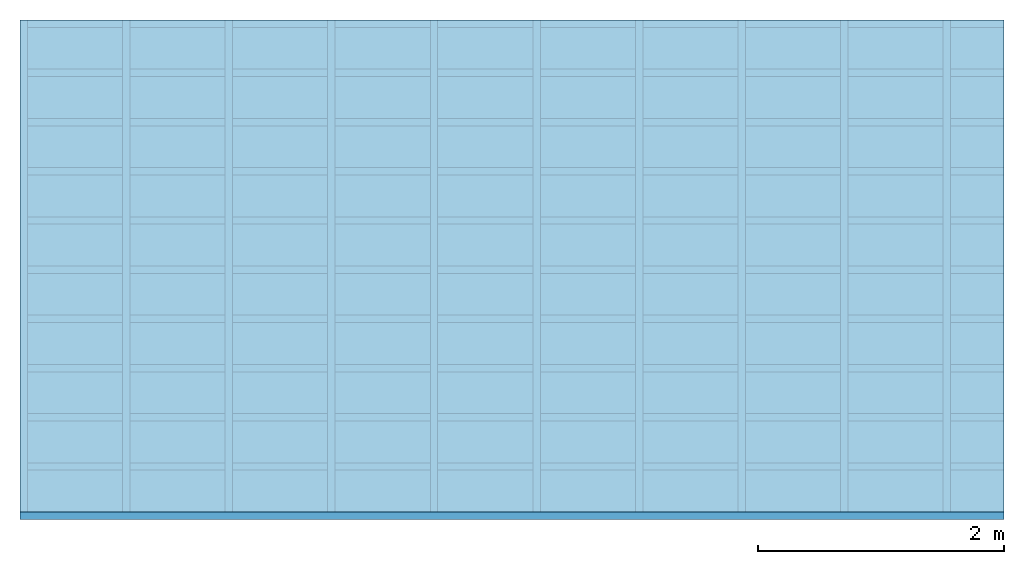
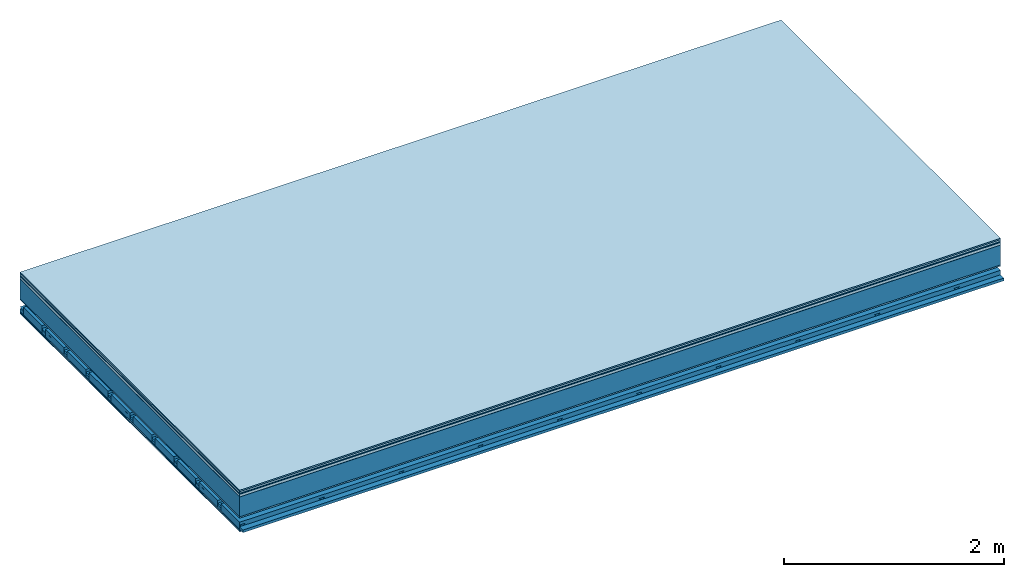
# One storey: 9 plates, 4 members, 1 element without a shape of its own.
"""IFC4 building model written with IfcOpenShell, lengths in metres."""

from ifc_helpers import new_model, si_unit, derived_unit, direction, frame, frame_2d, origin, origin_with_axes, place, context, project, spatial, polyline, rectangle, outline, extrude, material, layer, layer_set, type_object, element, aggregate, save


model = new_model("IFC4")

# Units and contexts
plan_context = context("Plan", 3, precision=1e-05, world=origin(), true_north=direction((0.0, 1.0)))
model_context = context("Model", 3, precision=1e-05, world=origin(), true_north=direction((0.0, 1.0)))
ifc_project = project(units=[si_unit("LENGTHUNIT", "METRE"), derived_unit("SOUNDPRESSUREUNIT", [(si_unit("PRESSUREUNIT", "PASCAL", prefix="MICRO"), 0)]), si_unit("ENERGYUNIT", "JOULE", prefix="MEGA"), si_unit("MASSUNIT", "GRAM", prefix="KILO"), derived_unit("THERMALTRANSMITTANCEUNIT", [(si_unit("POWERUNIT", "WATT"), 1), (si_unit("AREAUNIT", "SQUARE_METRE"), -1), (si_unit("THERMODYNAMICTEMPERATUREUNIT", "KELVIN"), -1)]), derived_unit("AREADENSITYUNIT", [(si_unit("MASSUNIT", "GRAM", prefix="KILO"), 1), (si_unit("AREAUNIT", "SQUARE_METRE"), -1)]), derived_unit("USERDEFINED", [(si_unit("ENERGYUNIT", "JOULE", prefix="MEGA"), 1), (si_unit("AREAUNIT", "SQUARE_METRE"), -1)])], contexts=[plan_context, model_context])

# Site, building, storey
site = spatial("IfcSite", under=ifc_project)
building_placement = place(None, origin())
building = spatial("IfcBuilding", under=site, at=building_placement)
storey_placement = place(building_placement, origin())
storey = spatial("IfcBuildingStorey", under=building, at=storey_placement)

# Slab, members, plates
ifc_material_1 = material(Category="11.013")
ifc_layer_1 = layer(ifc_material_1, 0.015, Name="Flooring")
ifc_material_2 = material(Category="03.007")
ifc_layer_2 = layer(ifc_material_2, 0.02, Name="On-material")
ifc_material_3 = material(Name="Wood fiber generic product", Category="10.009")
ifc_layer_3 = layer(ifc_material_3, 0.01, Name="Impact sound insulation")
ifc_material_4 = material(Name="with broken")
ifc_layer_4 = layer(ifc_material_4, 0.03, Name="on Supporting structure")
ifc_material_5 = material(Name="protection", Category="09.007")
ifc_layer_5 = layer(ifc_material_5, 0.0005, Name="Sub-floor")
ifc_material_6 = material(Name="no composite action")
ifc_layer_6 = layer(ifc_material_6, 0.0, Name="Bond")
ifc_layer_7 = layer(None, 0.22, Name="Supporting structure")
ifc_material_7 = material(Name="of the art")
ifc_layer_8 = layer(ifc_material_7, 0.0, Name="Bond")
ifc_layer_9 = layer(ifc_material_2, 0.015, Name="Lower layer 1")
ifc_layer_10 = layer(None, 0.095, Name="Coupling")
ifc_layer_11 = layer(None, 0.03, Name="Battens / profiles")
ifc_material_8 = material(Name="Plasterboard type A", Category="03.008")
ifc_layer_12 = layer(ifc_material_8, 0.0125, Name="Ceiling covering 1st layer")
ifc_layer_13 = layer(ifc_material_8, 0.0125, Name="Ceiling covering layer 2")
ifc_material_9 = material(Category="04.001")
ifc_layer_14 = layer(ifc_material_9, 0.003, Name="Surface / treatment")
ifc_layer_set = layer_set([ifc_layer_1, ifc_layer_2, ifc_layer_3, ifc_layer_4, ifc_layer_5, ifc_layer_6, ifc_layer_7, ifc_layer_8, ifc_layer_9, ifc_layer_10, ifc_layer_11, ifc_layer_12, ifc_layer_13, ifc_layer_14])
slab_type = type_object("IfcSlabType", Name="A2128", PredefinedType="NOTDEFINED", material=ifc_layer_set)
slab_placement = place(None, frame((0.0, 0.0, 0.0), z_axis=(0.0, 0.0, -1.0), x_axis=(1.0, 0.0, 0.0)))
slab = element("IfcSlab", 1, at=slab_placement, inside=storey, type_object=slab_type, material=ifc_layer_set, Name="Slab #1")
ifc_material_10 = material(Name="Solid timber panel")
member_1_placement = place(slab_placement, origin())
member_1 = element("IfcMember", 2, at=member_1_placement, material=ifc_material_10, Name="Supporting structure", context=plan_context, shape_type="SweptSolid", body=[
    extrude(rectangle(XDim=1.0, YDim=0.22, at=frame_2d((0.5, 0.11), x_axis=(1.0, 0.0))), frame((0.0, 4.0, 0.0755), z_axis=(0.0, -1.0, 0.0), x_axis=(1.0, 0.0, 0.0)), (0.0, 0.0, 1.0), 4.0),
    extrude(rectangle(XDim=1.0, YDim=0.22, at=frame_2d((0.5, 0.11), x_axis=(1.0, 0.0))), frame((1.0, 4.0, 0.0755), z_axis=(0.0, -1.0, 0.0), x_axis=(1.0, 0.0, 0.0)), (0.0, 0.0, 1.0), 4.0),
    extrude(rectangle(XDim=1.0, YDim=0.22, at=frame_2d((0.5, 0.11), x_axis=(1.0, 0.0))), frame((2.0, 4.0, 0.0755), z_axis=(0.0, -1.0, 0.0), x_axis=(1.0, 0.0, 0.0)), (0.0, 0.0, 1.0), 4.0),
    extrude(rectangle(XDim=1.0, YDim=0.22, at=frame_2d((0.5, 0.11), x_axis=(1.0, 0.0))), frame((3.0, 4.0, 0.0755), z_axis=(0.0, -1.0, 0.0), x_axis=(1.0, 0.0, 0.0)), (0.0, 0.0, 1.0), 4.0),
    extrude(rectangle(XDim=1.0, YDim=0.22, at=frame_2d((0.5, 0.11), x_axis=(1.0, 0.0))), frame((4.0, 4.0, 0.0755), z_axis=(0.0, -1.0, 0.0), x_axis=(1.0, 0.0, 0.0)), (0.0, 0.0, 1.0), 4.0),
    extrude(rectangle(XDim=1.0, YDim=0.22, at=frame_2d((0.5, 0.11), x_axis=(1.0, 0.0))), frame((5.0, 4.0, 0.0755), z_axis=(0.0, -1.0, 0.0), x_axis=(1.0, 0.0, 0.0)), (0.0, 0.0, 1.0), 4.0),
    extrude(rectangle(XDim=1.0, YDim=0.22, at=frame_2d((0.5, 0.11), x_axis=(1.0, 0.0))), frame((6.0, 4.0, 0.0755), z_axis=(0.0, -1.0, 0.0), x_axis=(1.0, 0.0, 0.0)), (0.0, 0.0, 1.0), 4.0),
    extrude(rectangle(XDim=1.0, YDim=0.22, at=frame_2d((0.5, 0.11), x_axis=(1.0, 0.0))), frame((7.0, 4.0, 0.0755), z_axis=(0.0, -1.0, 0.0), x_axis=(1.0, 0.0, 0.0)), (0.0, 0.0, 1.0), 4.0),
])
ifc_material_11 = material()
member_2_placement = place(slab_placement, origin())
member_2 = element("IfcMember", 3, at=member_2_placement, material=ifc_material_11, Name="Coupling", context=plan_context, shape_type="SweptSolid", body=[
    extrude(outline(polyline([(0.0, 0.0), (0.06, 0.0), (0.04, 0.02), (0.02, 0.02), (0.0, 0.0)])), frame((0.0, 4.0, 0.3855), z_axis=(0.0, -1.0, 0.0), x_axis=(1.0, 0.0, 0.0)), (0.0, 0.0, 1.0), 4.0),
    extrude(outline(polyline([(0.0, 0.0), (0.06, 0.0), (0.04, 0.02), (0.02, 0.02), (0.0, 0.0)])), frame((0.834, 4.0, 0.3855), z_axis=(0.0, -1.0, 0.0), x_axis=(1.0, 0.0, 0.0)), (0.0, 0.0, 1.0), 4.0),
    extrude(outline(polyline([(0.0, 0.0), (0.06, 0.0), (0.04, 0.02), (0.02, 0.02), (0.0, 0.0)])), frame((1.668, 4.0, 0.3855), z_axis=(0.0, -1.0, 0.0), x_axis=(1.0, 0.0, 0.0)), (0.0, 0.0, 1.0), 4.0),
    extrude(outline(polyline([(0.0, 0.0), (0.06, 0.0), (0.04, 0.02), (0.02, 0.02), (0.0, 0.0)])), frame((2.502, 4.0, 0.3855), z_axis=(0.0, -1.0, 0.0), x_axis=(1.0, 0.0, 0.0)), (0.0, 0.0, 1.0), 4.0),
    extrude(outline(polyline([(0.0, 0.0), (0.06, 0.0), (0.04, 0.02), (0.02, 0.02), (0.0, 0.0)])), frame((3.336, 4.0, 0.3855), z_axis=(0.0, -1.0, 0.0), x_axis=(1.0, 0.0, 0.0)), (0.0, 0.0, 1.0), 4.0),
    extrude(outline(polyline([(0.0, 0.0), (0.06, 0.0), (0.04, 0.02), (0.02, 0.02), (0.0, 0.0)])), frame((4.17, 4.0, 0.3855), z_axis=(0.0, -1.0, 0.0), x_axis=(1.0, 0.0, 0.0)), (0.0, 0.0, 1.0), 4.0),
    extrude(outline(polyline([(0.0, 0.0), (0.06, 0.0), (0.04, 0.02), (0.02, 0.02), (0.0, 0.0)])), frame((5.004, 4.0, 0.3855), z_axis=(0.0, -1.0, 0.0), x_axis=(1.0, 0.0, 0.0)), (0.0, 0.0, 1.0), 4.0),
    extrude(outline(polyline([(0.0, 0.0), (0.06, 0.0), (0.04, 0.02), (0.02, 0.02), (0.0, 0.0)])), frame((5.838, 4.0, 0.3855), z_axis=(0.0, -1.0, 0.0), x_axis=(1.0, 0.0, 0.0)), (0.0, 0.0, 1.0), 4.0),
    extrude(outline(polyline([(0.0, 0.0), (0.06, 0.0), (0.04, 0.02), (0.02, 0.02), (0.0, 0.0)])), frame((6.672, 4.0, 0.3855), z_axis=(0.0, -1.0, 0.0), x_axis=(1.0, 0.0, 0.0)), (0.0, 0.0, 1.0), 4.0),
    extrude(outline(polyline([(0.0, 0.0), (0.06, 0.0), (0.04, 0.02), (0.02, 0.02), (0.0, 0.0)])), frame((7.506, 4.0, 0.3855), z_axis=(0.0, -1.0, 0.0), x_axis=(1.0, 0.0, 0.0)), (0.0, 0.0, 1.0), 4.0),
])
member_3_placement = place(slab_placement, origin())
member_3 = element("IfcMember", 4, at=member_3_placement, material=ifc_material_11, Name="Battens / profiles", context=plan_context, shape_type="SweptSolid", body=[
    extrude(rectangle(XDim=0.06, YDim=0.03, at=frame_2d((0.03, 0.015), x_axis=(1.0, 0.0))), frame((0.0, 0.0, 0.4055), z_axis=(1.0, 0.0, 0.0), x_axis=(0.0, 1.0, 0.0)), (0.0, 0.0, 1.0), 8.0),
    extrude(rectangle(XDim=0.06, YDim=0.03, at=frame_2d((0.03, 0.015), x_axis=(1.0, 0.0))), frame((0.0, 0.4, 0.4055), z_axis=(1.0, 0.0, 0.0), x_axis=(0.0, 1.0, 0.0)), (0.0, 0.0, 1.0), 8.0),
    extrude(rectangle(XDim=0.06, YDim=0.03, at=frame_2d((0.03, 0.015), x_axis=(1.0, 0.0))), frame((0.0, 0.8, 0.4055), z_axis=(1.0, 0.0, 0.0), x_axis=(0.0, 1.0, 0.0)), (0.0, 0.0, 1.0), 8.0),
    extrude(rectangle(XDim=0.06, YDim=0.03, at=frame_2d((0.03, 0.015), x_axis=(1.0, 0.0))), frame((0.0, 1.2, 0.4055), z_axis=(1.0, 0.0, 0.0), x_axis=(0.0, 1.0, 0.0)), (0.0, 0.0, 1.0), 8.0),
    extrude(rectangle(XDim=0.06, YDim=0.03, at=frame_2d((0.03, 0.015), x_axis=(1.0, 0.0))), frame((0.0, 1.6, 0.4055), z_axis=(1.0, 0.0, 0.0), x_axis=(0.0, 1.0, 0.0)), (0.0, 0.0, 1.0), 8.0),
    extrude(rectangle(XDim=0.06, YDim=0.03, at=frame_2d((0.03, 0.015), x_axis=(1.0, 0.0))), frame((0.0, 2.0, 0.4055), z_axis=(1.0, 0.0, 0.0), x_axis=(0.0, 1.0, 0.0)), (0.0, 0.0, 1.0), 8.0),
    extrude(rectangle(XDim=0.06, YDim=0.03, at=frame_2d((0.03, 0.015), x_axis=(1.0, 0.0))), frame((0.0, 2.4, 0.4055), z_axis=(1.0, 0.0, 0.0), x_axis=(0.0, 1.0, 0.0)), (0.0, 0.0, 1.0), 8.0),
    extrude(rectangle(XDim=0.06, YDim=0.03, at=frame_2d((0.03, 0.015), x_axis=(1.0, 0.0))), frame((0.0, 2.8, 0.4055), z_axis=(1.0, 0.0, 0.0), x_axis=(0.0, 1.0, 0.0)), (0.0, 0.0, 1.0), 8.0),
    extrude(rectangle(XDim=0.06, YDim=0.03, at=frame_2d((0.03, 0.015), x_axis=(1.0, 0.0))), frame((0.0, 3.2, 0.4055), z_axis=(1.0, 0.0, 0.0), x_axis=(0.0, 1.0, 0.0)), (0.0, 0.0, 1.0), 8.0),
    extrude(rectangle(XDim=0.06, YDim=0.03, at=frame_2d((0.03, 0.015), x_axis=(1.0, 0.0))), frame((0.0, 3.6, 0.4055), z_axis=(1.0, 0.0, 0.0), x_axis=(0.0, 1.0, 0.0)), (0.0, 0.0, 1.0), 8.0),
    extrude(rectangle(XDim=0.06, YDim=0.03, at=frame_2d((0.03, 0.015), x_axis=(1.0, 0.0))), frame((0.0, 4.0, 0.4055), z_axis=(1.0, 0.0, 0.0), x_axis=(0.0, 1.0, 0.0)), (0.0, 0.0, 1.0), 8.0),
])
ifc_material_12 = material()
member_4_placement = place(slab_placement, origin())
member_4 = element("IfcMember", 5, at=member_4_placement, material=ifc_material_12, Name="Cavity", context=plan_context, shape_type="SweptSolid", body=[
    extrude(rectangle(XDim=0.34, YDim=0.08, at=frame_2d((0.17, 0.04), x_axis=(1.0, 0.0))), frame((0.0, 0.06, 0.3555), z_axis=(1.0, 0.0, 0.0), x_axis=(0.0, 1.0, 0.0)), (0.0, 0.0, 1.0), 8.0),
    extrude(rectangle(XDim=0.34, YDim=0.08, at=frame_2d((0.17, 0.04), x_axis=(1.0, 0.0))), frame((0.0, 0.46, 0.3555), z_axis=(1.0, 0.0, 0.0), x_axis=(0.0, 1.0, 0.0)), (0.0, 0.0, 1.0), 8.0),
    extrude(rectangle(XDim=0.34, YDim=0.08, at=frame_2d((0.17, 0.04), x_axis=(1.0, 0.0))), frame((0.0, 0.86, 0.3555), z_axis=(1.0, 0.0, 0.0), x_axis=(0.0, 1.0, 0.0)), (0.0, 0.0, 1.0), 8.0),
    extrude(rectangle(XDim=0.34, YDim=0.08, at=frame_2d((0.17, 0.04), x_axis=(1.0, 0.0))), frame((0.0, 1.26, 0.3555), z_axis=(1.0, 0.0, 0.0), x_axis=(0.0, 1.0, 0.0)), (0.0, 0.0, 1.0), 8.0),
    extrude(rectangle(XDim=0.34, YDim=0.08, at=frame_2d((0.17, 0.04), x_axis=(1.0, 0.0))), frame((0.0, 1.66, 0.3555), z_axis=(1.0, 0.0, 0.0), x_axis=(0.0, 1.0, 0.0)), (0.0, 0.0, 1.0), 8.0),
    extrude(rectangle(XDim=0.34, YDim=0.08, at=frame_2d((0.17, 0.04), x_axis=(1.0, 0.0))), frame((0.0, 2.06, 0.3555), z_axis=(1.0, 0.0, 0.0), x_axis=(0.0, 1.0, 0.0)), (0.0, 0.0, 1.0), 8.0),
    extrude(rectangle(XDim=0.34, YDim=0.08, at=frame_2d((0.17, 0.04), x_axis=(1.0, 0.0))), frame((0.0, 2.46, 0.3555), z_axis=(1.0, 0.0, 0.0), x_axis=(0.0, 1.0, 0.0)), (0.0, 0.0, 1.0), 8.0),
    extrude(rectangle(XDim=0.34, YDim=0.08, at=frame_2d((0.17, 0.04), x_axis=(1.0, 0.0))), frame((0.0, 2.86, 0.3555), z_axis=(1.0, 0.0, 0.0), x_axis=(0.0, 1.0, 0.0)), (0.0, 0.0, 1.0), 8.0),
    extrude(rectangle(XDim=0.34, YDim=0.08, at=frame_2d((0.17, 0.04), x_axis=(1.0, 0.0))), frame((0.0, 3.26, 0.3555), z_axis=(1.0, 0.0, 0.0), x_axis=(0.0, 1.0, 0.0)), (0.0, 0.0, 1.0), 8.0),
    extrude(rectangle(XDim=0.34, YDim=0.08, at=frame_2d((0.17, 0.04), x_axis=(1.0, 0.0))), frame((0.0, 3.66, 0.3555), z_axis=(1.0, 0.0, 0.0), x_axis=(0.0, 1.0, 0.0)), (0.0, 0.0, 1.0), 8.0),
])
plate_1_placement = place(slab_placement, origin())
plate_1 = element("IfcPlate", 6, at=plate_1_placement, material=ifc_material_1, Name="Flooring", context=plan_context, shape_type="SweptSolid", body=[
    extrude(rectangle(XDim=8.0, YDim=4.0, at=frame_2d((4.0, 2.0), x_axis=(1.0, 0.0))), origin_with_axes(), (0.0, 0.0, 1.0), 0.015),
])
plate_2_placement = place(slab_placement, origin())
plate_2 = element("IfcPlate", 7, at=plate_2_placement, material=ifc_material_2, Name="On-material", context=plan_context, shape_type="SweptSolid", body=[
    extrude(rectangle(XDim=8.0, YDim=4.0, at=frame_2d((4.0, 2.0), x_axis=(1.0, 0.0))), frame((0.0, 0.0, 0.015), z_axis=(0.0, 0.0, 1.0), x_axis=(1.0, 0.0, 0.0)), (0.0, 0.0, 1.0), 0.02),
])
plate_3_placement = place(slab_placement, origin())
plate_3 = element("IfcPlate", 8, at=plate_3_placement, material=ifc_material_3, Name="Impact sound insulation", context=plan_context, shape_type="SweptSolid", body=[
    extrude(rectangle(XDim=8.0, YDim=4.0, at=frame_2d((4.0, 2.0), x_axis=(1.0, 0.0))), frame((0.0, 0.0, 0.035), z_axis=(0.0, 0.0, 1.0), x_axis=(1.0, 0.0, 0.0)), (0.0, 0.0, 1.0), 0.01),
])
plate_4_placement = place(slab_placement, origin())
plate_4 = element("IfcPlate", 9, at=plate_4_placement, material=ifc_material_4, Name="on Supporting structure", context=plan_context, shape_type="SweptSolid", body=[
    extrude(rectangle(XDim=8.0, YDim=4.0, at=frame_2d((4.0, 2.0), x_axis=(1.0, 0.0))), frame((0.0, 0.0, 0.045), z_axis=(0.0, 0.0, 1.0), x_axis=(1.0, 0.0, 0.0)), (0.0, 0.0, 1.0), 0.03),
])
plate_5_placement = place(slab_placement, origin())
plate_5 = element("IfcPlate", 10, at=plate_5_placement, material=ifc_material_5, Name="Sub-floor", context=plan_context, shape_type="SweptSolid", body=[
    extrude(rectangle(XDim=8.0, YDim=4.0, at=frame_2d((4.0, 2.0), x_axis=(1.0, 0.0))), frame((0.0, 0.0, 0.075), z_axis=(0.0, 0.0, 1.0), x_axis=(1.0, 0.0, 0.0)), (0.0, 0.0, 1.0), 0.0005),
])
plate_6_placement = place(slab_placement, origin())
plate_6 = element("IfcPlate", 11, at=plate_6_placement, material=ifc_material_2, Name="Lower layer 1", context=plan_context, shape_type="SweptSolid", body=[
    extrude(rectangle(XDim=8.0, YDim=4.0, at=frame_2d((4.0, 2.0), x_axis=(1.0, 0.0))), frame((0.0, 0.0, 0.2955), z_axis=(0.0, 0.0, 1.0), x_axis=(1.0, 0.0, 0.0)), (0.0, 0.0, 1.0), 0.015),
])
plate_7_placement = place(slab_placement, origin())
plate_7 = element("IfcPlate", 12, at=plate_7_placement, material=ifc_material_8, Name="Ceiling covering 1st layer", context=plan_context, shape_type="SweptSolid", body=[
    extrude(rectangle(XDim=8.0, YDim=4.0, at=frame_2d((4.0, 2.0), x_axis=(1.0, 0.0))), frame((0.0, 0.0, 0.4355), z_axis=(0.0, 0.0, 1.0), x_axis=(1.0, 0.0, 0.0)), (0.0, 0.0, 1.0), 0.0125),
])
plate_8_placement = place(slab_placement, origin())
plate_8 = element("IfcPlate", 13, at=plate_8_placement, material=ifc_material_8, Name="Ceiling covering layer 2", context=plan_context, shape_type="SweptSolid", body=[
    extrude(rectangle(XDim=8.0, YDim=4.0, at=frame_2d((4.0, 2.0), x_axis=(1.0, 0.0))), frame((0.0, 0.0, 0.448), z_axis=(0.0, 0.0, 1.0), x_axis=(1.0, 0.0, 0.0)), (0.0, 0.0, 1.0), 0.0125),
])
plate_9_placement = place(slab_placement, origin())
plate_9 = element("IfcPlate", 14, at=plate_9_placement, material=ifc_material_9, Name="Surface / treatment", context=plan_context, shape_type="SweptSolid", body=[
    extrude(rectangle(XDim=8.0, YDim=4.0, at=frame_2d((4.0, 2.0), x_axis=(1.0, 0.0))), frame((0.0, 0.0, 0.4605), z_axis=(0.0, 0.0, 1.0), x_axis=(1.0, 0.0, 0.0)), (0.0, 0.0, 1.0), 0.003),
])
aggregate(slab, [plate_1, plate_2, plate_3, plate_4, plate_5, member_1, plate_6, member_2, member_3, member_4, plate_7, plate_8, plate_9])

save(model, "model.ifc")
